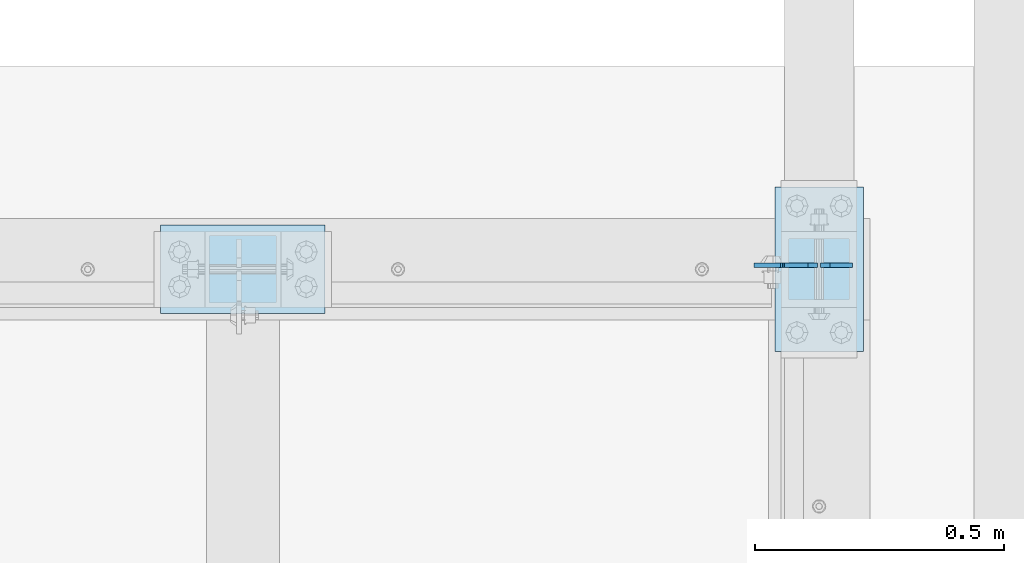
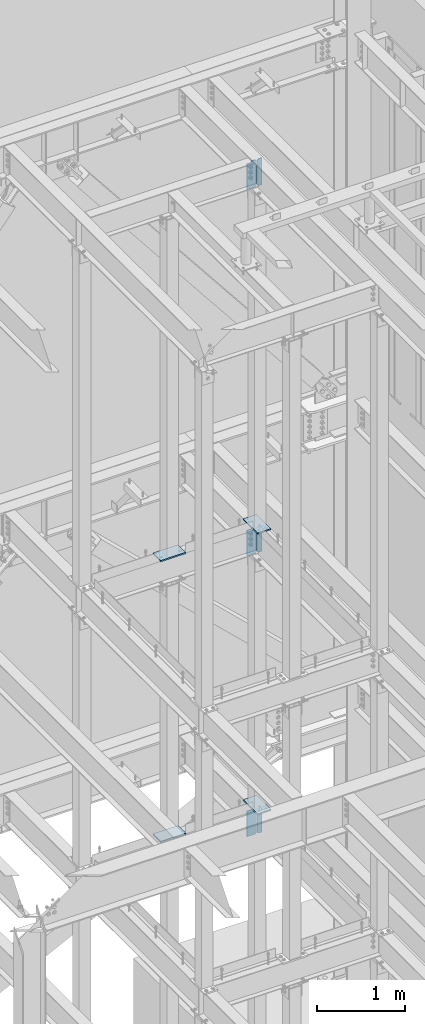
# One storey, part 1084 of 1179: 10 plates, 7 elements without a shape of their own.
"""IFC2X3 building model written with IfcOpenShell, lengths in millimetres."""

from ifc_helpers import new_model, si_unit, frame, origin_with_axes, place, context, subcontext, project, spatial, faceted_brep, material, type_object, element, aggregate, save


model = new_model("IFC2X3")

# Units and contexts
model_context = context("Model", 3, precision=1e-05, world=origin_with_axes())
body_context = subcontext(model_context, "Body", "Model", "MODEL_VIEW")
ifc_project = project(units=[si_unit("LENGTHUNIT", "METRE", prefix="MILLI"), si_unit("AREAUNIT", "SQUARE_METRE"), si_unit("VOLUMEUNIT", "CUBIC_METRE"), si_unit("MASSUNIT", "GRAM", prefix="KILO"), si_unit("TIMEUNIT", "SECOND"), si_unit("PLANEANGLEUNIT", "RADIAN"), si_unit("SOLIDANGLEUNIT", "STERADIAN"), si_unit("THERMODYNAMICTEMPERATUREUNIT", "DEGREE_CELSIUS"), si_unit("LUMINOUSINTENSITYUNIT", "LUMEN")], contexts=[model_context])

# Site, building, storey
site_placement = place(None, origin_with_axes())
site = spatial("IfcSite", under=ifc_project, at=site_placement, CompositionType="ELEMENT")
building_placement = place(site_placement, origin_with_axes())
building = spatial("IfcBuilding", under=site, at=building_placement, Name="Undefined", CompositionType="ELEMENT")
storey_placement = place(building_placement, origin_with_axes())
storey = spatial("IfcBuildingStorey", under=building, at=storey_placement, Name="Undefined", CompositionType="ELEMENT", Elevation=0.0)

# Assembly, plate
assembly_1_placement = place(storey_placement, origin_with_axes())
assembly_1 = element("IfcElementAssembly", 1, at=assembly_1_placement, inside=storey, Name="BEAM", AssemblyPlace="NOTDEFINED", PredefinedType="RIGID_FRAME")
ifc_material = material(Name="STEEL/A36")
plate_type_1 = type_object("IfcPlateType", PredefinedType="NOTDEFINED")
plate_1_placement = place(assembly_1_placement, frame((14182.725, 39441.4379999161, 7623.175), z_axis=(0.0, 0.0, 1.0), x_axis=(-1.0, 0.0, 0.0)))
plate_1 = element("IfcPlate", 2, at=plate_1_placement, type_object=plate_type_1, material=ifc_material, Name="PLATE", context=body_context, shape_type="Brep", body=[
    faceted_brep([(66.6749998164378, -4.76249999999709, 377.825), (66.6749999434469, -4.76249999999709, 371.474999553748), (66.6749999434469, 4.76249999999709, 371.474999553748), (66.6749998164378, 4.76249999999709, 377.825), (67.641729938794, -4.76249999999709, 366.614920114053), (67.641729938794, 4.76249999999709, 366.614920114053), (70.394743855788, -4.76249999999709, 362.494743732281), (70.394743855788, 4.76249999999709, 362.494743732281), (74.5149202922948, -4.76249999999709, 359.741729897201), (74.5149202922948, 4.76249999999709, 359.741729897201), (79.3749997512095, -4.76249999999709, 358.774999998475), (79.3749997512095, 4.76249999999709, 358.774999998475), (127.000000004868, -4.76249999999709, 358.774999992755), (127.0, 4.76249999999709, 358.774999992755), (0.0, -4.76249999999709, 358.775000762939), (19.0499992370605, -4.76249999999709, 377.825), (19.0499992370605, 4.76249999999709, 377.825), (0.0, 4.76249999999709, 358.775000762939), (0.0, -4.76250000000073, 19.0499992370605), (0.0, 4.76250000000073, 19.0499992370605), (19.0499992370605, -4.76250000000073, 0.0), (19.0499992370605, 4.76250000000073, 0.0), (127.0, -4.76250000000073, 0.0), (127.0, 4.76250000000073, 0.0)], [[[0, 1, 2, 3]], [[4, 5, 2, 1]], [[6, 7, 5, 4]], [[8, 9, 7, 6]], [[10, 11, 9, 8]], [[12, 13, 11, 10]], [[14, 15, 16, 17]], [[18, 14, 17, 19]], [[20, 18, 19, 21]], [[22, 20, 21, 23]], [[8, 6, 4, 1, 0, 15, 14, 18, 20, 22, 12, 10]], [[16, 15, 0, 3]], [[23, 21, 19, 17, 16, 3, 2, 5, 7, 9, 11, 13]], [[22, 23, 13, 12]]]),
])

assembly_2_placement = place(storey_placement, origin_with_axes())
assembly_2 = element("IfcElementAssembly", 3, at=assembly_2_placement, inside=storey, Name="BEAM", AssemblyPlace="NOTDEFINED", PredefinedType="RIGID_FRAME")
plate_2_placement = place(assembly_2_placement, frame((14182.7250422446, 39441.4380284119, 3711.575), z_axis=(0.0, 0.0, 1.0), x_axis=(-1.0, 0.0, 0.0)))
plate_2 = element("IfcPlate", 4, at=plate_2_placement, type_object=plate_type_1, material=ifc_material, Name="PLATE", context=body_context, shape_type="Brep", body=[
    faceted_brep([(66.6743865212811, -4.76249999999709, 377.825), (66.6745864763507, -4.76249999999709, 371.474599924168), (66.6745876193563, 4.76249999999709, 371.474599924203), (66.6743876643031, 4.76249999999709, 377.825), (67.6414311678836, -4.76249999999709, 366.614643208318), (67.6414323108893, 4.76249999999709, 366.614643208353), (70.3944716748138, -4.76249999999709, 362.494602443389), (70.3944728178176, 4.76249999999709, 362.494602443423), (74.5145991226364, -4.76249999999709, 359.741691665477), (74.514600265642, 4.76249999999709, 359.741691665511), (79.3745862790947, -4.76249999999709, 358.774999999796), (79.3745874221004, 4.76249999999709, 358.774999999831), (127.000000004868, -4.76249999999709, 358.774999992755), (127.0, 4.76249999999709, 358.774999992755), (0.0, -4.76249999999709, 358.775000762939), (19.0499992370605, -4.76249999999709, 377.825), (19.0499992370605, 4.76249999999709, 377.825), (0.0, 4.76249999999709, 358.775000762939), (0.0, -4.76250000000073, 19.0499992370605), (0.0, 4.76250000000073, 19.0499992370605), (19.0499992370605, -4.76250000000073, 0.0), (19.0499992370605, 4.76250000000073, 0.0), (127.0, -4.76250000000073, 0.0), (127.0, 4.76250000000073, 0.0)], [[[0, 1, 2, 3]], [[4, 5, 2, 1]], [[6, 7, 5, 4]], [[8, 9, 7, 6]], [[10, 11, 9, 8]], [[12, 13, 11, 10]], [[14, 15, 16, 17]], [[18, 14, 17, 19]], [[20, 18, 19, 21]], [[22, 20, 21, 23]], [[8, 6, 4, 1, 0, 15, 14, 18, 20, 22, 12, 10]], [[16, 15, 0, 3]], [[23, 21, 19, 17, 16, 3, 2, 5, 7, 9, 11, 13]], [[22, 23, 13, 12]]]),
])

assembly_3_placement = place(storey_placement, origin_with_axes())
assembly_3 = element("IfcElementAssembly", 5, at=assembly_3_placement, inside=storey, Name="BEAM", AssemblyPlace="NOTDEFINED", PredefinedType="RIGID_FRAME")
plate_3_placement = place(assembly_3_placement, frame((14182.725, 39441.4379999161, 12728.575), z_axis=(0.0, 0.0, 1.0), x_axis=(-1.0, 0.0, 0.0)))
plate_3 = element("IfcPlate", 6, at=plate_3_placement, type_object=plate_type_1, material=ifc_material, Name="PLATE", context=body_context, shape_type="Brep", body=[
    faceted_brep([(66.6749998164378, -4.76249999999709, 377.825), (66.6749999434469, -4.76249999999709, 371.474999553748), (66.6749999434469, 4.76249999999709, 371.474999553748), (66.6749998164378, 4.76249999999709, 377.825), (67.641729938794, -4.76249999999709, 366.614920114053), (67.641729938794, 4.76249999999709, 366.614920114053), (70.394743855788, -4.76249999999709, 362.494743732281), (70.394743855788, 4.76249999999709, 362.494743732281), (74.5149202922948, -4.76249999999709, 359.741729897201), (74.5149202922948, 4.76249999999709, 359.741729897201), (79.3749997512095, -4.76249999999709, 358.774999998475), (79.3749997512095, 4.76249999999709, 358.774999998475), (127.000000004868, -4.76249999999709, 358.774999992755), (127.0, 4.76249999999709, 358.774999992755), (0.0, -4.76249999999709, 358.775000762939), (19.0499992370605, -4.76249999999709, 377.825), (19.0499992370605, 4.76249999999709, 377.825), (0.0, 4.76249999999709, 358.775000762939), (0.0, -4.76250000000073, 19.0499992370605), (0.0, 4.76250000000073, 19.0499992370605), (19.0499992370605, -4.76250000000073, 0.0), (19.0499992370605, 4.76250000000073, 0.0), (127.0, -4.76250000000073, 0.0), (127.0, 4.76250000000073, 0.0)], [[[0, 1, 2, 3]], [[4, 5, 2, 1]], [[6, 7, 5, 4]], [[8, 9, 7, 6]], [[10, 11, 9, 8]], [[12, 13, 11, 10]], [[14, 15, 16, 17]], [[18, 14, 17, 19]], [[20, 18, 19, 21]], [[22, 20, 21, 23]], [[8, 6, 4, 1, 0, 15, 14, 18, 20, 22, 12, 10]], [[16, 15, 0, 3]], [[23, 21, 19, 17, 16, 3, 2, 5, 7, 9, 11, 13]], [[22, 23, 13, 12]]]),
])

assembly_4_placement = place(storey_placement, origin_with_axes())
assembly_4 = element("IfcElementAssembly", 7, at=assembly_4_placement, inside=storey, Name="COLUMN", AssemblyPlace="NOTDEFINED", PredefinedType="RIGID_FRAME")
plate_type_2 = type_object("IfcPlateType", PredefinedType="NOTDEFINED")
plate_4_placement = place(assembly_4_placement, frame((12865.1, 39522.4, 4111.625), z_axis=(1.0, 0.0, 0.0), x_axis=(0.0, -1.0, 0.0)))
plate_4 = element("IfcPlate", 8, at=plate_4_placement, type_object=plate_type_2, material=ifc_material, Name="PLATE", context=body_context, shape_type="Brep", body=[
    faceted_brep([(0.0, -9.52499999999964, 0.0), (0.0, -9.52499999999964, 330.200012207031), (0.0, 9.52499999999964, 330.200012207031), (0.0, 9.52499999999964, 0.0), (177.800003051758, -9.52499999999964, 330.200012207031), (177.800003051758, 9.52499999999964, 330.200012207031), (177.800003051758, -9.52499999999964, 0.0), (177.800003051758, 9.52499999999964, 0.0)], [[[0, 1, 2, 3]], [[1, 4, 5, 2]], [[4, 6, 7, 5]], [[6, 0, 3, 7]], [[5, 7, 3, 2]], [[6, 4, 1, 0]]]),
])
aggregate(assembly_4, [plate_4])

assembly_5_placement = place(storey_placement, origin_with_axes())
assembly_5 = element("IfcElementAssembly", 9, at=assembly_5_placement, inside=storey, Name="COLUMN", AssemblyPlace="NOTDEFINED", PredefinedType="RIGID_FRAME")
plate_5_placement = place(assembly_5_placement, frame((14096.999999999, 39268.4, 4111.625), z_axis=(0.0, 1.0, 0.0), x_axis=(1.0, 0.0, 0.0)))
plate_5 = element("IfcPlate", 10, at=plate_5_placement, type_object=plate_type_2, material=ifc_material, Name="PLATE", context=body_context, shape_type="Brep", body=[
    faceted_brep([(0.0, -9.52499999999964, 0.0), (0.0, -9.52499999999964, 330.200012207031), (0.0, 9.52499999999964, 330.200012207031), (0.0, 9.52499999999964, 0.0), (177.800003051758, -9.52499999999964, 330.200012207031), (177.800003051758, 9.52499999999964, 330.200012207031), (177.800003051758, -9.52499999999964, 0.0), (177.800003051758, 9.52499999999964, 0.0)], [[[0, 1, 2, 3]], [[1, 4, 5, 2]], [[4, 6, 7, 5]], [[6, 0, 3, 7]], [[5, 7, 3, 2]], [[6, 4, 1, 0]]]),
])
aggregate(assembly_5, [plate_5])

assembly_6_placement = place(storey_placement, origin_with_axes())
assembly_6 = element("IfcElementAssembly", 11, at=assembly_6_placement, inside=storey, Name="COLUMN", AssemblyPlace="NOTDEFINED", PredefinedType="RIGID_FRAME")
plate_6_placement = place(assembly_6_placement, frame((12865.1, 39522.4, 8023.225), z_axis=(1.0, 0.0, 0.0), x_axis=(0.0, -1.0, 0.0)))
plate_6 = element("IfcPlate", 12, at=plate_6_placement, type_object=plate_type_2, material=ifc_material, Name="PLATE", context=body_context, shape_type="Brep", body=[
    faceted_brep([(0.0, -9.52499999999964, 0.0), (0.0, -9.52499999999964, 330.200012207031), (0.0, 9.52499999999964, 330.200012207031), (0.0, 9.52499999999964, 0.0), (177.800003051758, -9.52499999999964, 330.200012207031), (177.800003051758, 9.52499999999964, 330.200012207031), (177.800003051758, -9.52499999999964, 0.0), (177.800003051758, 9.52499999999964, 0.0)], [[[0, 1, 2, 3]], [[1, 4, 5, 2]], [[4, 6, 7, 5]], [[6, 0, 3, 7]], [[5, 7, 3, 2]], [[6, 4, 1, 0]]]),
])
aggregate(assembly_6, [plate_6])

assembly_7_placement = place(storey_placement, origin_with_axes())
assembly_7 = element("IfcElementAssembly", 13, at=assembly_7_placement, inside=storey, Name="COLUMN", AssemblyPlace="NOTDEFINED", PredefinedType="RIGID_FRAME")
plate_7_placement = place(assembly_7_placement, frame((14097.0, 39268.4, 8023.225), z_axis=(0.0, 1.0, 0.0), x_axis=(1.0, 0.0, 0.0)))
plate_7 = element("IfcPlate", 14, at=plate_7_placement, type_object=plate_type_2, material=ifc_material, Name="PLATE", context=body_context, shape_type="Brep", body=[
    faceted_brep([(0.0, -9.52499999999964, 0.0), (0.0, -9.52499999999964, 330.200012207031), (0.0, 9.52499999999964, 330.200012207031), (0.0, 9.52499999999964, 0.0), (177.800003051758, -9.52499999999964, 330.200012207031), (177.800003051758, 9.52499999999964, 330.200012207031), (177.800003051758, -9.52499999999964, 0.0), (177.800003051758, 9.52499999999964, 0.0)], [[[0, 1, 2, 3]], [[1, 4, 5, 2]], [[4, 6, 7, 5]], [[6, 0, 3, 7]], [[5, 7, 3, 2]], [[6, 4, 1, 0]]]),
])
aggregate(assembly_7, [plate_7])

# Plate
plate_type_3 = type_object("IfcPlateType", PredefinedType="NOTDEFINED")
plate_8_placement = place(assembly_1_placement, frame((14189.075, 39441.4379999161, 7623.175), z_axis=(0.0, 0.0, 1.0), x_axis=(1.0, 0.0, 0.0)))
plate_8 = element("IfcPlate", 15, at=plate_8_placement, type_object=plate_type_3, material=ifc_material, Name="PLATE", context=body_context, shape_type="Brep", body=[
    faceted_brep([(0.0, -4.76250000000073, 19.0499992370605), (0.0, -4.76249999999709, 358.775000762939), (0.0, 4.76249999999709, 358.775000762939), (0.0, 4.76250000000073, 19.0499992370605), (19.0499992370605, -4.76249999999709, 377.825), (19.0499992370605, 4.76249999999709, 377.825), (63.5, -4.76250000000073, 377.825012207031), (63.5, 4.76250000000073, 377.825012207031), (63.5, -4.76250000000073, 0.0), (63.5, 4.76250000000073, 0.0), (19.0499992370605, -4.76250000000073, 0.0), (19.0499992370605, 4.76250000000073, 0.0)], [[[0, 1, 2, 3]], [[1, 4, 5, 2]], [[4, 6, 7, 5]], [[6, 8, 9, 7]], [[8, 10, 11, 9]], [[10, 0, 3, 11]], [[5, 7, 9, 11, 3, 2]], [[10, 8, 6, 4, 1, 0]]]),
])

aggregate(assembly_1, [plate_8, plate_1])

plate_9_placement = place(assembly_2_placement, frame((14189.0750423637, 39441.4380285668, 3711.575), z_axis=(0.0, 0.0, 1.0), x_axis=(1.0, 0.0, 0.0)))
plate_9 = element("IfcPlate", 16, at=plate_9_placement, type_object=plate_type_3, material=ifc_material, Name="PLATE", context=body_context, shape_type="Brep", body=[
    faceted_brep([(0.0, -4.76250000000073, 19.0499992370605), (0.0, -4.76249999999709, 358.775000762939), (0.0, 4.76249999999709, 358.775000762939), (0.0, 4.76250000000073, 19.0499992370605), (19.0499992370605, -4.76249999999709, 377.825), (19.0499992370605, 4.76249999999709, 377.825), (63.5, -4.76250000000073, 377.825012207031), (63.5, 4.76250000000073, 377.825012207031), (63.5, -4.76250000000073, 0.0), (63.5, 4.76250000000073, 0.0), (19.0499992370605, -4.76250000000073, 0.0), (19.0499992370605, 4.76250000000073, 0.0)], [[[0, 1, 2, 3]], [[1, 4, 5, 2]], [[4, 6, 7, 5]], [[6, 8, 9, 7]], [[8, 10, 11, 9]], [[10, 0, 3, 11]], [[5, 7, 9, 11, 3, 2]], [[10, 8, 6, 4, 1, 0]]]),
])

aggregate(assembly_2, [plate_9, plate_2])

plate_10_placement = place(assembly_3_placement, frame((14189.075, 39441.4379999161, 12728.575), z_axis=(0.0, 0.0, 1.0), x_axis=(1.0, 0.0, 0.0)))
plate_10 = element("IfcPlate", 17, at=plate_10_placement, type_object=plate_type_3, material=ifc_material, Name="PLATE", context=body_context, shape_type="Brep", body=[
    faceted_brep([(0.0, -4.76250000000073, 19.0499992370605), (0.0, -4.76249999999709, 358.775000762939), (0.0, 4.76249999999709, 358.775000762939), (0.0, 4.76250000000073, 19.0499992370605), (19.0499992370605, -4.76249999999709, 377.825), (19.0499992370605, 4.76249999999709, 377.825), (63.5, -4.76250000000073, 377.825012207031), (63.5, 4.76250000000073, 377.825012207031), (63.5, -4.76250000000073, 0.0), (63.5, 4.76250000000073, 0.0), (19.0499992370605, -4.76250000000073, 0.0), (19.0499992370605, 4.76250000000073, 0.0)], [[[0, 1, 2, 3]], [[1, 4, 5, 2]], [[4, 6, 7, 5]], [[6, 8, 9, 7]], [[8, 10, 11, 9]], [[10, 0, 3, 11]], [[5, 7, 9, 11, 3, 2]], [[10, 8, 6, 4, 1, 0]]]),
])

aggregate(assembly_3, [plate_10, plate_3])

save(model, "model.ifc")
